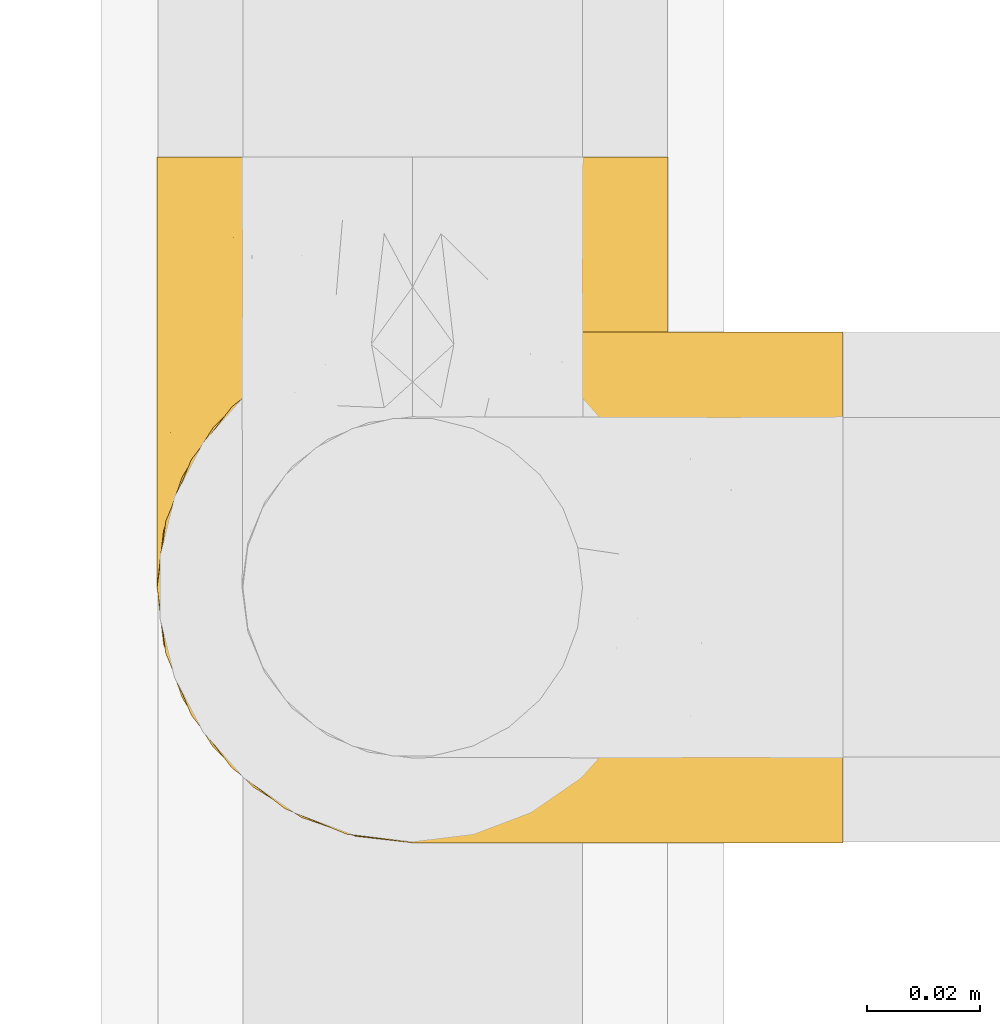
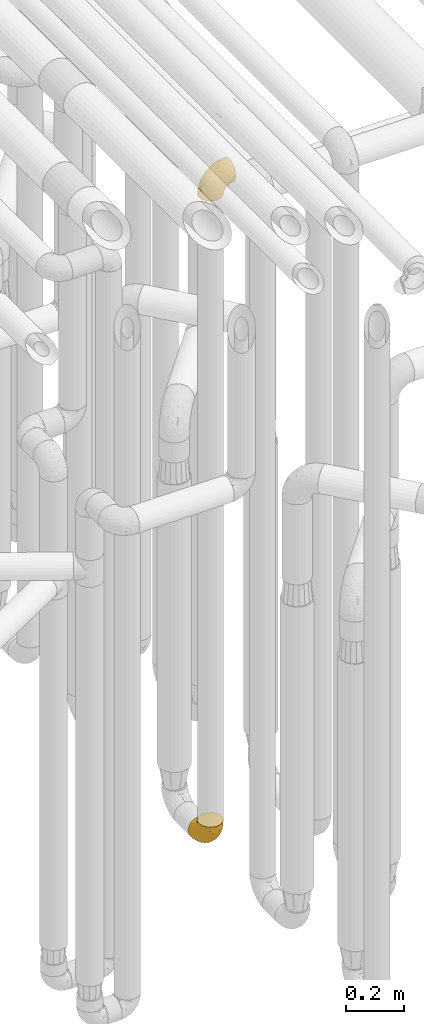
# One storey, part 204 of 827: 2 coverings.
"""IFC2X3 building model written with IfcOpenShell, lengths in millimetres."""

from ifc_helpers import new_model, entity, si_unit, converted_unit, derived_unit, direction, frame, origin, place, context, subcontext, project, spatial, faceted_brep, element, save


model = new_model("IFC2X3")

# Units and contexts
model_context = context("Model", 3, precision=0.01, world=origin(), true_north=direction((6.12303176911189e-17, 1.0)))
body_context = subcontext(model_context, "Body", "Model", "MODEL_VIEW")
ifc_project = project(units=[si_unit("LENGTHUNIT", "METRE", prefix="MILLI"), si_unit("AREAUNIT", "SQUARE_METRE"), si_unit("VOLUMEUNIT", "CUBIC_METRE"), converted_unit("PLANEANGLEUNIT", "DEGREE", entity("IfcRatioMeasure", 0.0174532925199433), si_unit("PLANEANGLEUNIT", "RADIAN"), dimensions=[0, 0, 0, 0, 0, 0, 0]), si_unit("MASSUNIT", "GRAM", prefix="KILO"), derived_unit("MASSDENSITYUNIT", [(si_unit("MASSUNIT", "GRAM", prefix="KILO"), 1), (si_unit("LENGTHUNIT", "METRE"), -3)]), derived_unit("MOMENTOFINERTIAUNIT", [(si_unit("LENGTHUNIT", "METRE"), 4)]), si_unit("TIMEUNIT", "SECOND"), si_unit("FREQUENCYUNIT", "HERTZ"), si_unit("THERMODYNAMICTEMPERATUREUNIT", "DEGREE_CELSIUS"), derived_unit("THERMALTRANSMITTANCEUNIT", [(si_unit("MASSUNIT", "GRAM", prefix="KILO"), 1), (si_unit("THERMODYNAMICTEMPERATUREUNIT", "KELVIN"), -1), (si_unit("TIMEUNIT", "SECOND"), -3)]), derived_unit("VOLUMETRICFLOWRATEUNIT", [(si_unit("LENGTHUNIT", "METRE"), 3), (si_unit("TIMEUNIT", "SECOND"), -1)]), derived_unit("MASSFLOWRATEUNIT", [(si_unit("MASSUNIT", "GRAM", prefix="KILO"), 1), (si_unit("TIMEUNIT", "SECOND"), -1)]), derived_unit("ROTATIONALFREQUENCYUNIT", [(si_unit("TIMEUNIT", "SECOND"), -1)]), si_unit("ELECTRICCURRENTUNIT", "AMPERE"), si_unit("ELECTRICVOLTAGEUNIT", "VOLT"), si_unit("POWERUNIT", "WATT"), si_unit("FORCEUNIT", "NEWTON", prefix="KILO"), si_unit("ILLUMINANCEUNIT", "LUX"), si_unit("LUMINOUSFLUXUNIT", "LUMEN"), si_unit("LUMINOUSINTENSITYUNIT", "CANDELA"), derived_unit("USERDEFINED", [(si_unit("MASSUNIT", "GRAM", prefix="KILO"), -1), (si_unit("LENGTHUNIT", "METRE"), -2), (si_unit("TIMEUNIT", "SECOND"), 3), (si_unit("LUMINOUSFLUXUNIT", "LUMEN"), 1)]), derived_unit("LINEARVELOCITYUNIT", [(si_unit("LENGTHUNIT", "METRE"), 1), (si_unit("TIMEUNIT", "SECOND"), -1)]), si_unit("PRESSUREUNIT", "PASCAL"), derived_unit("USERDEFINED", [(si_unit("LENGTHUNIT", "METRE"), -2), (si_unit("MASSUNIT", "GRAM", prefix="KILO"), 1), (si_unit("TIMEUNIT", "SECOND"), -2)]), derived_unit("LINEARFORCEUNIT", [(si_unit("MASSUNIT", "GRAM", prefix="KILO"), 1), (si_unit("LENGTHUNIT", "METRE"), 1), (si_unit("TIMEUNIT", "SECOND"), -2), (si_unit("LENGTHUNIT", "METRE"), -1)]), derived_unit("PLANARFORCEUNIT", [(si_unit("MASSUNIT", "GRAM", prefix="KILO"), 1), (si_unit("LENGTHUNIT", "METRE"), 1), (si_unit("TIMEUNIT", "SECOND"), -2), (si_unit("LENGTHUNIT", "METRE"), -2)])], contexts=[model_context])

# Site, building, storey
site_placement = place(None, origin())
site = spatial("IfcSite", under=ifc_project, at=site_placement, CompositionType="ELEMENT")
building_placement = place(site_placement, origin())
building = spatial("IfcBuilding", under=site, at=building_placement, CompositionType="ELEMENT")
storey_placement = place(building_placement, frame((0.0, 0.0, 28200.0)))
storey = spatial("IfcBuildingStorey", under=building, at=storey_placement, Name="08", CompositionType="ELEMENT", Elevation=28200.0)

# Coverings
covering_1_placement = place(storey_placement, frame((36582.9, 11034.43, 353.25)))
element("IfcCovering", 1, at=covering_1_placement, inside=storey, Name=":ADSK_", ObjectType=":ADSK_", PredefinedType="INSULATION", context=body_context, shape_type="Brep", body=[
    faceted_brep([(2.73, 36.69, 122.75), (6.07, 27.15, 122.75), (11.45, 18.59, 122.75), (18.6, 11.44, 122.75), (27.16, 6.06, 122.75), (36.7, 2.73, 122.75), (46.75, 1.6, 122.75), (56.8, 2.73, 122.75), (66.34, 6.07, 122.75), (74.9, 11.45, 122.75), (82.05, 18.6, 122.75), (87.43, 27.16, 122.75), (90.76, 36.7, 122.75), (91.9, 46.75, 122.75), (90.76, 56.8, 122.75), (87.42, 66.34, 122.75), (82.04, 74.9, 122.75), (74.89, 82.05, 122.75), (66.33, 87.43, 122.75), (56.79, 90.76, 122.75), (46.75, 91.9, 122.75), (36.69, 90.76, 122.75), (27.15, 87.42, 122.75), (18.59, 82.04, 122.75), (11.44, 74.89, 122.75), (6.06, 66.33, 122.75), (2.73, 56.79, 122.75), (1.6, 46.75, 122.75), (58.43, 122.75, 90.36), (69.32, 122.75, 85.85), (78.67, 122.75, 78.67), (85.85, 122.75, 69.32), (90.36, 122.75, 58.43), (91.9, 122.75, 46.75), (90.36, 122.75, 35.06), (85.85, 122.75, 24.17), (78.67, 122.75, 14.82), (69.32, 122.75, 7.64), (58.43, 122.75, 3.13), (46.75, 122.75, 1.6), (35.06, 122.75, 3.13), (24.17, 122.75, 7.64), (14.82, 122.75, 14.82), (7.64, 122.75, 24.17), (3.13, 122.75, 35.06), (1.6, 122.75, 46.75), (3.13, 122.75, 58.43), (7.64, 122.75, 69.32), (14.82, 122.75, 78.67), (24.17, 122.75, 85.85), (35.06, 122.75, 90.36), (46.75, 122.75, 91.9), (46.75, 24.73, 51.54), (38.29, 29.08, 47.17), (46.75, 38.13, 38.13), (46.75, 85.31, 7.52), (38.96, 93.59, 5.85), (46.75, 100.54, 5.11), (33.86, 63.54, 19.2), (31.42, 38.98, 38.98), (21.63, 50.71, 35.02), (30.84, 93.33, 8.21), (22.16, 75.2, 19.28), (20.56, 100.46, 12.19), (2.29, 41.6, 101.39), (7.18, 80.86, 34.43), (12.6, 94.87, 20.95), (14.0, 67.96, 30.74), (2.81, 52.16, 72.93), (6.65, 52.1, 56.64), (6.11, 36.74, 80.81), (16.62, 17.11, 93.43), (9.76, 23.24, 100.76), (12.46, 29.18, 74.27), (1.6, 52.53, 93.66), (1.6, 60.77, 81.33), (1.6, 69.01, 69.01), (2.46, 100.68, 40.87), (5.91, 103.79, 29.38), (36.97, 16.37, 67.05), (46.75, 7.52, 85.31), (33.09, 7.31, 93.68), (1.6, 93.66, 52.53), (1.6, 102.83, 50.71), (1.6, 112.01, 48.88), (25.62, 18.17, 72.77), (3.14, 71.97, 51.21), (23.92, 9.83, 101.18), (46.75, 5.11, 100.54), (13.58, 45.97, 48.74), (1.6, 48.88, 112.01), (1.6, 50.71, 102.83), (18.5, 22.83, 73.88), (46.75, 51.54, 24.73), (1.6, 81.33, 60.77), (4.96, 31.74, 103.08), (20.84, 32.48, 54.8), (46.75, 68.42, 16.13), (30.52, 25.33, 55.92), (46.75, 16.13, 68.42), (27.29, 92.29, 104.98), (36.89, 94.12, 108.58), (33.6, 100.97, 98.21), (2.54, 95.91, 61.56), (3.27, 107.9, 60.69), (16.85, 87.24, 100.0), (21.91, 95.46, 95.88), (13.5, 90.41, 90.81), (3.96, 74.17, 84.88), (3.52, 83.77, 73.29), (12.17, 76.72, 113.4), (18.93, 84.44, 109.8), (9.34, 76.42, 102.13), (3.12, 90.07, 67.29), (5.67, 99.69, 70.34), (2.51, 61.74, 95.15), (2.53, 58.16, 105.49), (8.35, 112.6, 71.5), (35.39, 110.45, 92.87), (46.75, 107.32, 96.03), (15.1, 108.48, 81.34), (5.27, 66.63, 107.44), (27.43, 115.23, 88.36), (24.89, 105.79, 90.43), (29.71, 89.6, 114.37), (5.07, 69.39, 98.41), (2.88, 66.99, 88.73), (9.69, 102.31, 76.89), (15.51, 99.54, 86.08), (2.27, 55.27, 112.64), (10.03, 82.03, 94.21), (46.75, 94.71, 112.22), (46.75, 96.03, 107.32), (8.83, 94.11, 79.95), (7.16, 84.21, 84.51), (46.75, 101.67, 101.67), (46.75, 112.22, 94.71), (78.39, 108.48, 81.34), (83.8, 102.31, 76.89), (77.97, 99.54, 86.08), (84.66, 94.11, 79.96), (58.1, 110.46, 92.87), (81.31, 76.74, 113.41), (91.9, 50.71, 102.83), (90.96, 58.17, 105.5), (91.22, 55.27, 112.64), (56.59, 94.12, 108.58), (66.18, 92.3, 104.98), (59.87, 100.98, 98.2), (88.42, 69.41, 98.4), (84.13, 76.44, 102.13), (88.22, 66.65, 107.44), (66.06, 115.24, 88.36), (91.9, 102.83, 50.71), (91.9, 112.01, 48.88), (83.44, 82.05, 94.22), (76.62, 87.25, 100.01), (85.14, 112.6, 71.5), (90.22, 107.9, 60.69), (91.9, 93.66, 52.53), (71.55, 95.48, 95.89), (63.77, 89.6, 114.37), (91.9, 60.77, 81.33), (91.9, 69.01, 69.01), (89.53, 74.17, 84.88), (91.9, 48.88, 112.01), (74.55, 84.45, 109.8), (90.95, 95.91, 61.56), (90.37, 90.07, 67.29), (91.9, 81.33, 60.77), (90.98, 61.75, 95.14), (89.97, 83.77, 73.29), (86.32, 84.21, 84.53), (91.9, 52.53, 93.66), (79.97, 90.42, 90.82), (90.61, 67.0, 88.73), (87.82, 99.69, 70.34), (68.6, 105.8, 90.43), (80.89, 94.87, 20.95), (86.31, 80.86, 34.43), (79.49, 67.95, 30.74), (71.33, 75.17, 19.29), (71.88, 50.65, 35.07), (90.35, 71.97, 51.21), (86.85, 52.08, 56.67), (72.67, 32.46, 54.85), (62.08, 38.98, 38.98), (87.58, 103.79, 29.38), (91.03, 100.68, 40.87), (59.62, 63.54, 19.2), (62.65, 93.32, 8.21), (54.53, 93.59, 5.85), (72.93, 100.44, 12.19), (90.68, 52.17, 72.93), (87.39, 36.75, 80.83), (91.2, 41.61, 101.39), (60.41, 7.31, 93.69), (76.88, 17.12, 93.43), (56.53, 16.37, 67.04), (83.74, 23.26, 100.76), (67.88, 18.17, 72.78), (62.99, 25.33, 55.93), (69.58, 9.84, 101.18), (81.04, 29.19, 74.27), (75.0, 22.84, 73.89), (88.53, 31.75, 103.09), (79.93, 45.96, 48.78), (55.21, 29.07, 47.19)], [[[0, 1, 2, 3, 4, 5, 6, 7, 8, 9, 10, 11, 12, 13, 14, 15, 16, 17, 18, 19, 20, 21, 22, 23, 24, 25, 26, 27]], [[28, 29, 30, 31, 32, 33, 34, 35, 36, 37, 38, 39, 40, 41, 42, 43, 44, 45, 46, 47, 48, 49, 50, 51]], [[52, 53, 54]], [[55, 56, 57]], [[58, 59, 60]], [[61, 62, 63]], [[27, 64, 0]], [[65, 66, 67]], [[41, 40, 61]], [[68, 69, 70]], [[66, 43, 42]], [[63, 42, 41]], [[71, 72, 73]], [[72, 2, 1]], [[68, 74, 75, 76]], [[45, 44, 77]], [[43, 78, 44]], [[79, 80, 81]], [[77, 82, 83, 84, 45]], [[79, 81, 85]], [[71, 2, 72]], [[65, 86, 77]], [[4, 81, 5]], [[66, 65, 78]], [[4, 3, 87]], [[81, 88, 5]], [[63, 66, 42]], [[68, 70, 64]], [[67, 60, 89]], [[71, 3, 2]], [[64, 27, 90, 91, 74]], [[92, 71, 73]], [[40, 57, 56]], [[59, 93, 54]], [[86, 76, 94, 82]], [[1, 0, 95]], [[58, 62, 61]], [[60, 96, 89]], [[85, 81, 87]], [[56, 97, 58]], [[65, 67, 69]], [[87, 81, 4]], [[67, 89, 69]], [[61, 63, 41]], [[95, 72, 1]], [[73, 72, 70]], [[69, 73, 70]], [[73, 89, 96]], [[3, 71, 87]], [[85, 87, 71]], [[58, 61, 56]], [[59, 58, 93]], [[76, 86, 68]], [[69, 89, 73]], [[68, 86, 69]], [[65, 69, 86]], [[68, 64, 74]], [[95, 64, 70]], [[98, 79, 85]], [[79, 52, 99, 80]], [[66, 62, 67]], [[62, 58, 60]], [[62, 60, 67]], [[59, 98, 96]], [[59, 96, 60]], [[96, 85, 92]], [[88, 81, 80]], [[88, 6, 5]], [[66, 63, 62]], [[64, 95, 0]], [[72, 95, 70]], [[77, 44, 78]], [[86, 82, 77]], [[40, 39, 57]], [[96, 98, 85]], [[40, 56, 61]], [[66, 78, 43]], [[77, 78, 65]], [[79, 98, 53]], [[96, 92, 73]], [[85, 71, 92]], [[97, 56, 55]], [[97, 93, 58]], [[53, 98, 59]], [[54, 53, 59]], [[79, 53, 52]], [[100, 101, 102]], [[46, 45, 84, 83]], [[103, 104, 82]], [[82, 104, 83]], [[105, 106, 107]], [[108, 109, 76]], [[110, 111, 112]], [[103, 113, 114]], [[115, 74, 116]], [[48, 47, 117]], [[118, 102, 119]], [[49, 48, 120]], [[74, 91, 116]], [[116, 121, 115]], [[49, 122, 50]], [[123, 106, 102]], [[124, 111, 22]], [[125, 126, 115]], [[23, 22, 111]], [[24, 110, 121]], [[120, 127, 128]], [[90, 26, 129]], [[27, 26, 90]], [[121, 125, 115]], [[24, 121, 25]], [[130, 105, 107]], [[129, 25, 116]], [[21, 20, 131]], [[120, 123, 122]], [[112, 105, 130]], [[50, 118, 51]], [[21, 124, 22]], [[101, 131, 132]], [[117, 120, 48]], [[24, 23, 110]], [[127, 114, 133]], [[75, 108, 76]], [[107, 134, 130]], [[133, 114, 113]], [[129, 116, 91]], [[25, 121, 116]], [[121, 112, 125]], [[75, 74, 115]], [[101, 135, 102]], [[131, 101, 21]], [[101, 100, 124]], [[128, 127, 133]], [[119, 136, 51, 118]], [[104, 47, 46]], [[83, 104, 46]], [[117, 104, 114]], [[101, 124, 21]], [[111, 124, 100]], [[102, 118, 123]], [[133, 134, 107]], [[111, 110, 23]], [[114, 104, 103]], [[94, 76, 109]], [[121, 110, 112]], [[122, 118, 50]], [[134, 109, 108]], [[133, 107, 128]], [[112, 108, 125]], [[126, 125, 108]], [[108, 75, 126]], [[75, 115, 126]], [[109, 134, 133]], [[130, 108, 112]], [[108, 130, 134]], [[105, 112, 111]], [[111, 100, 105]], [[106, 105, 100]], [[102, 106, 100]], [[128, 106, 123]], [[90, 129, 91]], [[25, 129, 26]], [[104, 117, 47]], [[117, 114, 127]], [[82, 94, 103]], [[113, 94, 109]], [[94, 113, 103]], [[133, 113, 109]], [[106, 128, 107]], [[123, 120, 128]], [[120, 122, 49]], [[118, 122, 123]], [[135, 101, 132]], [[135, 119, 102]], [[117, 127, 120]], [[30, 29, 137]], [[138, 139, 140]], [[51, 136, 119, 141]], [[142, 17, 16]], [[143, 144, 145]], [[146, 147, 148]], [[149, 150, 151]], [[152, 29, 28]], [[33, 32, 153, 154]], [[150, 155, 156]], [[157, 31, 30]], [[153, 158, 159]], [[29, 152, 137]], [[148, 141, 119]], [[156, 160, 147]], [[148, 135, 146]], [[137, 138, 157]], [[19, 161, 146]], [[162, 163, 164]], [[14, 13, 165]], [[153, 32, 158]], [[147, 161, 166]], [[18, 17, 166]], [[167, 168, 169]], [[166, 150, 156]], [[151, 150, 142]], [[151, 170, 149]], [[151, 16, 15]], [[171, 140, 172]], [[165, 143, 145]], [[173, 170, 144]], [[142, 166, 17]], [[19, 131, 20]], [[144, 170, 151]], [[18, 161, 19]], [[173, 144, 143]], [[140, 139, 174]], [[171, 164, 163]], [[164, 172, 155]], [[151, 15, 144]], [[145, 15, 14]], [[173, 162, 170]], [[149, 175, 164]], [[19, 146, 131]], [[132, 131, 146]], [[160, 148, 147]], [[159, 158, 167]], [[135, 132, 146]], [[158, 32, 31]], [[157, 158, 31]], [[167, 158, 176]], [[166, 161, 18]], [[146, 161, 147]], [[148, 177, 141]], [[171, 168, 140]], [[171, 163, 169]], [[151, 142, 16]], [[166, 142, 150]], [[152, 141, 177]], [[51, 141, 28]], [[138, 140, 176]], [[172, 140, 174]], [[175, 149, 170]], [[164, 150, 149]], [[170, 162, 175]], [[162, 164, 175]], [[155, 172, 174]], [[171, 172, 164]], [[155, 174, 156]], [[164, 155, 150]], [[160, 156, 174]], [[147, 166, 156]], [[139, 160, 174]], [[148, 160, 177]], [[15, 145, 144]], [[165, 145, 14]], [[137, 157, 30]], [[158, 157, 176]], [[168, 167, 176]], [[169, 159, 167]], [[140, 168, 176]], [[169, 168, 171]], [[137, 177, 139]], [[160, 139, 177]], [[141, 152, 28]], [[137, 152, 177]], [[148, 119, 135]], [[157, 138, 176]], [[139, 138, 137]], [[178, 179, 180]], [[181, 180, 182]], [[179, 183, 184]], [[185, 186, 182]], [[187, 188, 179]], [[188, 33, 154, 153, 159]], [[181, 189, 190]], [[35, 34, 187]], [[191, 38, 190]], [[192, 178, 181]], [[179, 184, 180]], [[192, 190, 37]], [[37, 190, 38]], [[36, 35, 178]], [[54, 93, 186]], [[35, 187, 178]], [[193, 194, 184]], [[195, 173, 143, 165, 13]], [[195, 193, 173]], [[193, 163, 162, 173]], [[13, 12, 195]], [[8, 7, 196]], [[9, 197, 10]], [[198, 80, 99, 52]], [[196, 7, 88]], [[197, 199, 10]], [[182, 189, 181]], [[200, 198, 201]], [[200, 196, 198]], [[9, 8, 202]], [[194, 199, 203]], [[192, 37, 36]], [[80, 196, 88]], [[183, 159, 169, 163]], [[188, 34, 33]], [[202, 200, 197]], [[185, 203, 204]], [[202, 8, 196]], [[10, 199, 11]], [[12, 11, 205]], [[38, 191, 57]], [[189, 97, 191]], [[203, 199, 197]], [[205, 199, 194]], [[204, 203, 197]], [[184, 203, 206]], [[200, 202, 196]], [[197, 9, 202]], [[207, 54, 186]], [[97, 55, 191]], [[194, 203, 184]], [[183, 163, 193]], [[184, 206, 180]], [[183, 193, 184]], [[205, 195, 12]], [[193, 195, 194]], [[80, 198, 196]], [[207, 186, 201]], [[182, 180, 206]], [[181, 178, 180]], [[185, 182, 206]], [[182, 186, 189]], [[203, 185, 206]], [[185, 200, 201]], [[7, 6, 88]], [[178, 192, 36]], [[190, 192, 181]], [[199, 205, 11]], [[195, 205, 194]], [[159, 183, 188]], [[179, 188, 183]], [[57, 191, 55]], [[57, 39, 38]], [[189, 191, 190]], [[188, 187, 34]], [[178, 187, 179]], [[186, 93, 189]], [[197, 200, 204]], [[185, 204, 200]], [[189, 93, 97]], [[207, 198, 52]], [[185, 201, 186]], [[198, 207, 201]], [[54, 207, 52]]]),
])
covering_2_placement = place(storey_placement, frame((36582.9, 11034.43, 3122.4)))
element("IfcCovering", 2, at=covering_2_placement, inside=storey, Name=":ADSK_", ObjectType=":ADSK_", PredefinedType="INSULATION", context=body_context, shape_type="Brep", body=[
    faceted_brep([(122.75, 90.76, 87.65), (122.75, 87.42, 97.19), (122.75, 82.04, 105.75), (122.75, 74.89, 112.9), (122.75, 66.33, 118.28), (122.75, 56.79, 121.61), (122.75, 46.75, 122.75), (122.75, 36.69, 121.61), (122.75, 27.15, 118.27), (122.75, 18.59, 112.89), (122.75, 11.44, 105.74), (122.75, 6.06, 97.18), (122.75, 2.73, 87.64), (122.75, 1.6, 77.6), (122.75, 2.73, 67.54), (122.75, 6.07, 58.0), (122.75, 11.45, 49.44), (122.75, 18.6, 42.29), (122.75, 27.16, 36.91), (122.75, 36.7, 33.58), (122.75, 46.75, 32.45), (122.75, 56.8, 33.58), (122.75, 66.34, 36.92), (122.75, 74.9, 42.3), (122.75, 82.05, 49.45), (122.75, 87.43, 58.01), (122.75, 90.76, 67.55), (122.75, 91.9, 77.6), (90.36, 35.06, 1.6), (85.85, 24.17, 1.6), (78.67, 14.82, 1.6), (69.32, 7.64, 1.6), (58.43, 3.13, 1.6), (46.75, 1.6, 1.6), (35.06, 3.13, 1.6), (24.17, 7.64, 1.6), (14.82, 14.82, 1.6), (7.64, 24.17, 1.6), (3.13, 35.06, 1.6), (1.6, 46.75, 1.6), (3.13, 58.43, 1.6), (7.64, 69.32, 1.6), (14.82, 78.67, 1.6), (24.17, 85.85, 1.6), (35.06, 90.36, 1.6), (46.75, 91.9, 1.6), (58.43, 90.36, 1.6), (69.32, 85.85, 1.6), (78.67, 78.67, 1.6), (85.85, 69.32, 1.6), (90.36, 58.43, 1.6), (91.9, 46.75, 1.6), (51.54, 46.75, 99.61), (47.17, 55.2, 95.26), (38.13, 46.75, 86.21), (7.52, 46.75, 39.03), (5.85, 54.53, 30.75), (5.11, 46.75, 23.8), (19.2, 59.63, 60.8), (38.98, 62.07, 85.37), (35.02, 71.86, 73.64), (8.21, 62.65, 31.01), (19.28, 71.33, 49.14), (12.19, 72.93, 23.88), (101.39, 91.2, 82.74), (34.43, 86.31, 43.48), (20.95, 80.89, 29.47), (30.74, 79.49, 56.38), (72.93, 90.68, 72.18), (56.64, 86.84, 72.24), (80.81, 87.38, 87.6), (93.43, 76.87, 107.24), (100.76, 83.73, 101.1), (74.27, 81.03, 95.16), (93.66, 91.9, 71.81), (81.33, 91.9, 63.57), (69.01, 91.9, 55.34), (40.87, 91.03, 23.66), (29.38, 87.58, 20.55), (67.05, 56.52, 107.97), (85.31, 46.75, 116.82), (93.68, 60.4, 117.03), (52.53, 91.9, 30.68), (50.71, 91.9, 21.51), (48.88, 91.9, 12.33), (72.77, 67.87, 106.17), (51.21, 90.35, 52.37), (101.18, 69.57, 114.51), (100.54, 46.75, 119.23), (48.74, 79.91, 78.37), (112.01, 91.9, 75.46), (102.83, 91.9, 73.63), (73.88, 74.99, 101.51), (24.73, 46.75, 72.81), (60.77, 91.9, 43.01), (103.08, 88.53, 92.6), (54.8, 72.65, 91.86), (16.13, 46.75, 55.92), (55.92, 62.97, 99.01), (68.42, 46.75, 108.21), (104.98, 66.2, 32.05), (108.58, 56.6, 30.22), (98.21, 59.89, 23.37), (61.56, 90.95, 28.43), (60.69, 90.22, 16.44), (100.0, 76.64, 37.1), (95.88, 71.58, 28.88), (90.81, 79.99, 33.93), (84.88, 89.54, 50.17), (73.29, 89.97, 40.57), (113.4, 81.32, 47.62), (109.8, 74.56, 39.9), (102.13, 84.15, 47.92), (67.29, 90.37, 34.27), (70.34, 87.82, 24.65), (95.15, 90.98, 62.6), (105.49, 90.96, 66.18), (71.5, 85.14, 11.74), (92.87, 58.11, 13.89), (96.03, 46.75, 17.02), (81.34, 78.39, 15.86), (107.44, 88.22, 57.71), (88.36, 66.06, 9.11), (90.43, 68.6, 18.55), (114.37, 63.78, 34.74), (98.41, 88.42, 54.95), (88.73, 90.61, 57.35), (76.89, 83.8, 22.03), (86.08, 77.98, 24.8), (112.64, 91.22, 69.07), (94.21, 83.46, 42.31), (112.22, 46.75, 29.63), (107.32, 46.75, 28.31), (79.95, 84.66, 30.23), (84.51, 86.33, 40.13), (101.67, 46.75, 22.67), (94.71, 46.75, 12.12), (81.34, 15.1, 15.86), (76.89, 9.69, 22.03), (86.08, 15.52, 24.8), (79.96, 8.83, 30.23), (92.87, 35.39, 13.88), (113.41, 12.18, 47.61), (102.83, 1.6, 73.63), (105.5, 2.53, 66.17), (112.64, 2.27, 69.07), (108.58, 36.9, 30.22), (104.98, 27.31, 32.04), (98.2, 33.62, 23.36), (98.4, 5.07, 54.93), (102.13, 9.36, 47.91), (107.44, 5.27, 57.69), (88.36, 27.43, 9.1), (50.71, 1.6, 21.51), (48.88, 1.6, 12.33), (94.22, 10.05, 42.29), (100.01, 16.87, 37.09), (71.5, 8.35, 11.74), (60.69, 3.27, 16.44), (52.53, 1.6, 30.68), (95.89, 21.94, 28.86), (114.37, 29.72, 34.74), (81.33, 1.6, 63.57), (69.01, 1.6, 55.34), (84.88, 3.96, 50.17), (112.01, 1.6, 75.46), (109.8, 18.95, 39.89), (61.56, 2.54, 28.43), (67.29, 3.12, 34.27), (60.77, 1.6, 43.01), (95.14, 2.51, 62.59), (73.29, 3.52, 40.57), (84.53, 7.17, 40.13), (93.66, 1.6, 71.81), (90.82, 13.52, 33.92), (88.73, 2.88, 57.34), (70.34, 5.67, 24.65), (90.43, 24.89, 18.54), (20.95, 12.6, 29.47), (34.43, 7.18, 43.48), (30.74, 14.0, 56.4), (19.29, 22.16, 49.17), (35.07, 21.61, 73.69), (51.21, 3.14, 52.37), (56.67, 6.65, 72.26), (54.85, 20.82, 91.88), (38.98, 31.41, 85.36), (29.38, 5.91, 20.55), (40.87, 2.46, 23.66), (19.2, 33.87, 60.8), (8.21, 30.84, 31.02), (5.85, 38.96, 30.75), (12.19, 20.56, 23.9), (72.93, 2.81, 72.17), (80.83, 6.1, 87.59), (101.39, 2.29, 82.74), (93.69, 33.08, 117.03), (93.43, 16.61, 107.23), (67.04, 36.96, 107.97), (100.76, 9.75, 101.08), (72.78, 25.61, 106.17), (55.93, 30.5, 99.01), (101.18, 23.91, 114.5), (74.27, 12.45, 95.15), (73.89, 18.49, 101.5), (103.09, 4.96, 92.59), (48.78, 13.56, 78.38), (47.19, 38.28, 95.27)], [[[0, 1, 2, 3, 4, 5, 6, 7, 8, 9, 10, 11, 12, 13, 14, 15, 16, 17, 18, 19, 20, 21, 22, 23, 24, 25, 26, 27]], [[28, 29, 30, 31, 32, 33, 34, 35, 36, 37, 38, 39, 40, 41, 42, 43, 44, 45, 46, 47, 48, 49, 50, 51]], [[52, 53, 54]], [[55, 56, 57]], [[58, 59, 60]], [[61, 62, 63]], [[27, 64, 0]], [[65, 66, 67]], [[41, 40, 61]], [[68, 69, 70]], [[66, 43, 42]], [[63, 42, 41]], [[71, 72, 73]], [[72, 2, 1]], [[68, 74, 75, 76]], [[45, 44, 77]], [[43, 78, 44]], [[79, 80, 81]], [[77, 82, 83, 84, 45]], [[79, 81, 85]], [[71, 2, 72]], [[65, 86, 77]], [[4, 81, 5]], [[66, 65, 78]], [[4, 3, 87]], [[81, 88, 5]], [[63, 66, 42]], [[68, 70, 64]], [[67, 60, 89]], [[71, 3, 2]], [[64, 27, 90, 91, 74]], [[92, 71, 73]], [[40, 57, 56]], [[59, 93, 54]], [[86, 76, 94, 82]], [[1, 0, 95]], [[58, 62, 61]], [[60, 96, 89]], [[85, 81, 87]], [[56, 97, 58]], [[65, 67, 69]], [[87, 81, 4]], [[67, 89, 69]], [[61, 63, 41]], [[95, 72, 1]], [[73, 72, 70]], [[69, 73, 70]], [[73, 89, 96]], [[3, 71, 87]], [[85, 87, 71]], [[58, 61, 56]], [[59, 58, 93]], [[76, 86, 68]], [[69, 89, 73]], [[68, 86, 69]], [[65, 69, 86]], [[68, 64, 74]], [[95, 64, 70]], [[98, 79, 85]], [[79, 52, 99, 80]], [[66, 62, 67]], [[62, 58, 60]], [[62, 60, 67]], [[59, 98, 96]], [[59, 96, 60]], [[96, 85, 92]], [[88, 81, 80]], [[88, 6, 5]], [[66, 63, 62]], [[64, 95, 0]], [[72, 95, 70]], [[77, 44, 78]], [[86, 82, 77]], [[40, 39, 57]], [[96, 98, 85]], [[40, 56, 61]], [[66, 78, 43]], [[77, 78, 65]], [[79, 98, 53]], [[96, 92, 73]], [[85, 71, 92]], [[97, 56, 55]], [[97, 93, 58]], [[53, 98, 59]], [[54, 53, 59]], [[79, 53, 52]], [[100, 101, 102]], [[46, 45, 84, 83]], [[103, 104, 82]], [[82, 104, 83]], [[105, 106, 107]], [[108, 109, 76]], [[110, 111, 112]], [[103, 113, 114]], [[115, 74, 116]], [[48, 47, 117]], [[118, 102, 119]], [[49, 48, 120]], [[74, 91, 116]], [[116, 121, 115]], [[49, 122, 50]], [[123, 106, 102]], [[124, 111, 22]], [[125, 126, 115]], [[23, 22, 111]], [[24, 110, 121]], [[120, 127, 128]], [[90, 26, 129]], [[27, 26, 90]], [[121, 125, 115]], [[24, 121, 25]], [[130, 105, 107]], [[129, 25, 116]], [[21, 20, 131]], [[120, 123, 122]], [[112, 105, 130]], [[50, 118, 51]], [[21, 124, 22]], [[101, 131, 132]], [[117, 120, 48]], [[24, 23, 110]], [[127, 114, 133]], [[75, 108, 76]], [[107, 134, 130]], [[133, 114, 113]], [[129, 116, 91]], [[25, 121, 116]], [[121, 112, 125]], [[75, 74, 115]], [[101, 135, 102]], [[131, 101, 21]], [[101, 100, 124]], [[128, 127, 133]], [[119, 136, 51, 118]], [[104, 47, 46]], [[83, 104, 46]], [[117, 104, 114]], [[101, 124, 21]], [[111, 124, 100]], [[102, 118, 123]], [[133, 134, 107]], [[111, 110, 23]], [[114, 104, 103]], [[94, 76, 109]], [[121, 110, 112]], [[122, 118, 50]], [[134, 109, 108]], [[133, 107, 128]], [[112, 108, 125]], [[126, 125, 108]], [[108, 75, 126]], [[75, 115, 126]], [[109, 134, 133]], [[130, 108, 112]], [[108, 130, 134]], [[105, 112, 111]], [[111, 100, 105]], [[106, 105, 100]], [[102, 106, 100]], [[128, 106, 123]], [[90, 129, 91]], [[25, 129, 26]], [[104, 117, 47]], [[117, 114, 127]], [[82, 94, 103]], [[113, 94, 109]], [[94, 113, 103]], [[133, 113, 109]], [[106, 128, 107]], [[123, 120, 128]], [[120, 122, 49]], [[118, 122, 123]], [[135, 101, 132]], [[135, 119, 102]], [[117, 127, 120]], [[30, 29, 137]], [[138, 139, 140]], [[51, 136, 119, 141]], [[142, 17, 16]], [[143, 144, 145]], [[146, 147, 148]], [[149, 150, 151]], [[152, 29, 28]], [[33, 32, 153, 154]], [[150, 155, 156]], [[157, 31, 30]], [[153, 158, 159]], [[29, 152, 137]], [[148, 141, 119]], [[156, 160, 147]], [[148, 135, 146]], [[137, 138, 157]], [[19, 161, 146]], [[162, 163, 164]], [[14, 13, 165]], [[153, 32, 158]], [[147, 161, 166]], [[18, 17, 166]], [[167, 168, 169]], [[166, 150, 156]], [[151, 150, 142]], [[151, 170, 149]], [[151, 16, 15]], [[171, 140, 172]], [[165, 143, 145]], [[173, 170, 144]], [[142, 166, 17]], [[19, 131, 20]], [[144, 170, 151]], [[18, 161, 19]], [[173, 144, 143]], [[140, 139, 174]], [[171, 164, 163]], [[164, 172, 155]], [[151, 15, 144]], [[145, 15, 14]], [[173, 162, 170]], [[149, 175, 164]], [[19, 146, 131]], [[132, 131, 146]], [[160, 148, 147]], [[159, 158, 167]], [[135, 132, 146]], [[158, 32, 31]], [[157, 158, 31]], [[167, 158, 176]], [[166, 161, 18]], [[146, 161, 147]], [[148, 177, 141]], [[171, 168, 140]], [[171, 163, 169]], [[151, 142, 16]], [[166, 142, 150]], [[152, 141, 177]], [[51, 141, 28]], [[138, 140, 176]], [[172, 140, 174]], [[175, 149, 170]], [[164, 150, 149]], [[170, 162, 175]], [[162, 164, 175]], [[155, 172, 174]], [[171, 172, 164]], [[155, 174, 156]], [[164, 155, 150]], [[160, 156, 174]], [[147, 166, 156]], [[139, 160, 174]], [[148, 160, 177]], [[15, 145, 144]], [[165, 145, 14]], [[137, 157, 30]], [[158, 157, 176]], [[168, 167, 176]], [[169, 159, 167]], [[140, 168, 176]], [[169, 168, 171]], [[137, 177, 139]], [[160, 139, 177]], [[141, 152, 28]], [[137, 152, 177]], [[148, 119, 135]], [[157, 138, 176]], [[139, 138, 137]], [[178, 179, 180]], [[181, 180, 182]], [[179, 183, 184]], [[185, 186, 182]], [[187, 188, 179]], [[188, 33, 154, 153, 159]], [[181, 189, 190]], [[35, 34, 187]], [[191, 38, 190]], [[192, 178, 181]], [[179, 184, 180]], [[192, 190, 37]], [[37, 190, 38]], [[36, 35, 178]], [[54, 93, 186]], [[35, 187, 178]], [[193, 194, 184]], [[195, 173, 143, 165, 13]], [[195, 193, 173]], [[193, 163, 162, 173]], [[13, 12, 195]], [[8, 7, 196]], [[9, 197, 10]], [[198, 80, 99, 52]], [[196, 7, 88]], [[197, 199, 10]], [[182, 189, 181]], [[200, 198, 201]], [[200, 196, 198]], [[9, 8, 202]], [[194, 199, 203]], [[192, 37, 36]], [[80, 196, 88]], [[183, 159, 169, 163]], [[188, 34, 33]], [[202, 200, 197]], [[185, 203, 204]], [[202, 8, 196]], [[10, 199, 11]], [[12, 11, 205]], [[38, 191, 57]], [[189, 97, 191]], [[203, 199, 197]], [[205, 199, 194]], [[204, 203, 197]], [[184, 203, 206]], [[200, 202, 196]], [[197, 9, 202]], [[207, 54, 186]], [[97, 55, 191]], [[194, 203, 184]], [[183, 163, 193]], [[184, 206, 180]], [[183, 193, 184]], [[205, 195, 12]], [[193, 195, 194]], [[80, 198, 196]], [[207, 186, 201]], [[182, 180, 206]], [[181, 178, 180]], [[185, 182, 206]], [[182, 186, 189]], [[203, 185, 206]], [[185, 200, 201]], [[7, 6, 88]], [[178, 192, 36]], [[190, 192, 181]], [[199, 205, 11]], [[195, 205, 194]], [[159, 183, 188]], [[179, 188, 183]], [[57, 191, 55]], [[57, 39, 38]], [[189, 191, 190]], [[188, 187, 34]], [[178, 187, 179]], [[186, 93, 189]], [[197, 200, 204]], [[185, 204, 200]], [[189, 93, 97]], [[207, 198, 52]], [[185, 201, 186]], [[198, 207, 201]], [[54, 207, 52]]]),
])

save(model, "model.ifc")
